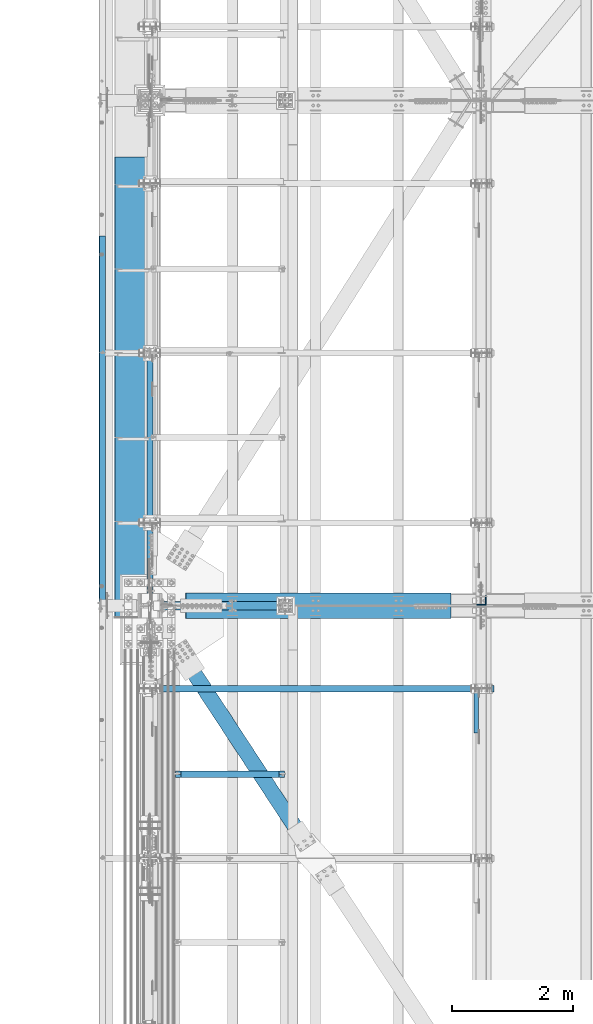
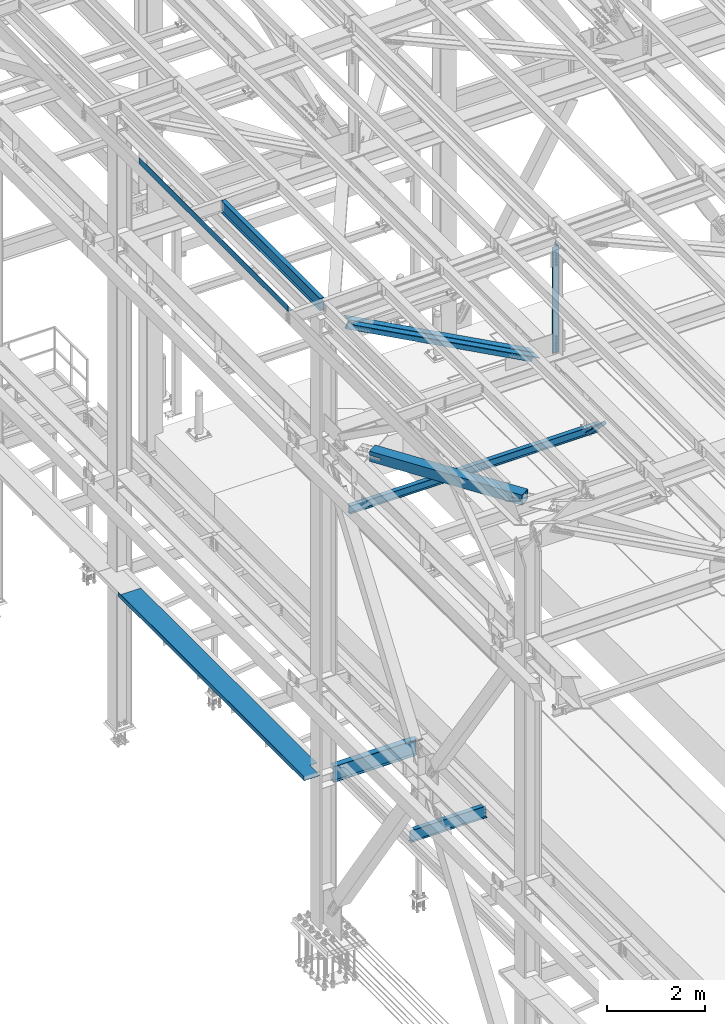
# One storey, part 1873 of 3843: 8 beams, 3 members, 11 elements without a shape of their own.
"""IFC2X3 building model written with IfcOpenShell, lengths in millimetres."""

from ifc_helpers import new_model, si_unit, frame, origin_with_axes, place, context, subcontext, project, spatial, faceted_brep, material, type_object, element, aggregate, save


model = new_model("IFC2X3")

# Units and contexts
model_context = context("Model", 3, precision=1e-05, world=origin_with_axes())
body_context = subcontext(model_context, "Body", "Model", "MODEL_VIEW")
ifc_project = project(units=[si_unit("LENGTHUNIT", "METRE", prefix="MILLI"), si_unit("AREAUNIT", "SQUARE_METRE"), si_unit("VOLUMEUNIT", "CUBIC_METRE"), si_unit("MASSUNIT", "GRAM", prefix="KILO"), si_unit("TIMEUNIT", "SECOND"), si_unit("PLANEANGLEUNIT", "RADIAN"), si_unit("SOLIDANGLEUNIT", "STERADIAN"), si_unit("THERMODYNAMICTEMPERATUREUNIT", "DEGREE_CELSIUS"), si_unit("LUMINOUSINTENSITYUNIT", "LUMEN")], contexts=[model_context])

# Site, building, storey
site_placement = place(None, origin_with_axes())
site = spatial("IfcSite", under=ifc_project, at=site_placement, CompositionType="ELEMENT")
building_placement = place(site_placement, origin_with_axes())
building = spatial("IfcBuilding", under=site, at=building_placement, Name="Undefined", CompositionType="ELEMENT")
storey_placement = place(building_placement, origin_with_axes())
storey = spatial("IfcBuildingStorey", under=building, at=storey_placement, Name="Undefined", CompositionType="ELEMENT", Elevation=0.0)

# Assembly, beam
assembly_1_placement = place(storey_placement, origin_with_axes())
assembly_1 = element("IfcElementAssembly", 1, at=assembly_1_placement, inside=storey, Name="BEAM", AssemblyPlace="NOTDEFINED", PredefinedType="RIGID_FRAME")
ifc_material_1 = material(Name="STEEL/A36")
beam_type_1 = type_object("IfcBeamType", PredefinedType="NOTDEFINED")
beam_1_placement = place(assembly_1_placement, frame((35839.3101110438, 78692.375, 45717.1843160686), z_axis=(0.0, -1.0, 0.0), x_axis=(-0.999776270257024, 0.0, -0.0211520550054595)))
beam_1 = element("IfcBeam", 2, at=beam_1_placement, type_object=beam_type_1, material=ifc_material_1, Name="BENT_PLATE", context=body_context, shape_type="Brep", body=[
    faceted_brep([(-3.50355549016967e-07, -3.17499999742722, -3048.00000001723), (3.50421032635495e-07, -3.17500000260043, 3048.00000001724), (3.5035191103816e-07, 3.17499999739084, 3048.00000001724), (-3.50424670614302e-07, 3.17500000256405, -3048.00000001723), (101.599999864371, 3.17499999856227, 3048.00000000522), (101.599998739839, 3.17500000373548, -3048.00000002925), (95.249998765099, -3.17499999632128, -3048.00000002851), (95.2499998896274, -3.17500000149448, 3048.00000000597), (101.600000309205, -161.925000875126, 3047.9999999938), (101.599999608374, -161.925000446165, -3048.00000004067), (95.2500003092064, -161.925000900388, 3047.99999999456), (95.2499996083752, -161.925000471427, -3048.00000003992)], [[[0, 1, 2, 3]], [[3, 2, 4, 5]], [[1, 0, 6, 7]], [[5, 4, 8, 9]], [[4, 2, 1, 7, 10, 8]], [[7, 6, 11, 10]], [[6, 0, 3, 5, 9, 11]], [[10, 11, 9, 8]]]),
])
aggregate(assembly_1, [beam_1])

assembly_2_placement = place(storey_placement, origin_with_axes())
assembly_2 = element("IfcElementAssembly", 3, at=assembly_2_placement, inside=storey, Name="BEAM", AssemblyPlace="NOTDEFINED", PredefinedType="RIGID_FRAME")
ifc_material_2 = material(Name="STEEL/A992")
beam_type_2 = type_object("IfcBeamType", Name="W12X19", PredefinedType="NOTDEFINED")
beam_2_placement = place(assembly_2_placement, frame((36575.9999999912, 75628.5, 45575.6071293693), z_axis=(0.0, 0.0, 1.0), x_axis=(0.0, 1.0, 0.0)))
beam_2 = element("IfcBeam", 4, at=beam_2_placement, type_object=beam_type_2, material=ifc_material_2, Name="BEAM", ObjectType="W12X19", context=body_context, shape_type="Brep", body=[
    faceted_brep([(15.8750000000146, -3.17500000000291, -128.587499998961), (15.8750000000146, 3.17500000000291, -128.587499998961), (53.9750001907523, 3.17500000000291, -128.587499998961), (53.9750001907523, -3.17500000000291, -128.587499998961), (58.8350797087915, 3.17500000000291, -129.554229921552), (58.8350797087915, -3.17500000000291, -129.554229921552), (62.9552561769524, 3.17500000000291, -132.307243822026), (62.9552561769524, -3.17500000000291, -132.307243822026), (65.7082700774336, 3.17500000000291, -136.42742029018), (65.7082700774336, -3.17500000000291, -136.42742029018), (66.6750000000175, -3.17500000000291, -141.287499808226), (66.6750000000175, 3.17500000000291, -141.287499808226), (66.6750000000175, 3.17500000000291, -144.462500000001), (66.6750000000175, 50.8000000000029, -144.462500000001), (66.6750000000175, 50.8000000000029, -153.987500000003), (66.6750000000175, -50.8000000000029, -153.987500000003), (66.6750000000175, -50.8000000000029, -144.462500000001), (66.6750000000175, -3.17500000000291, -144.462500000001), (4111.62499999991, 50.8000000000029, 144.462500000001), (4111.62499999991, 3.17500000000291, 144.462500000001), (66.6750000000175, 3.17500000000291, 144.462500000001), (66.6750000000175, 50.8000000000029, 144.462500000001), (53.9750001907523, -3.17500000000291, 128.587500001042), (53.9750001907523, 3.17500000000291, 128.587500001042), (15.8750000000146, 3.17500000000291, 128.587500001042), (15.8750000000146, -3.17500000000291, 128.587500001042), (58.8350797087915, -3.17500000000291, 129.554229923633), (58.8350797087915, 3.17500000000291, 129.554229923633), (62.9552561769524, -3.17500000000291, 132.307243824107), (62.9552561769524, 3.17500000000291, 132.307243824107), (65.7082700774336, -3.17500000000291, 136.427420292261), (65.7082700774336, 3.17500000000291, 136.427420292261), (66.6750000000175, -3.17500000000291, 141.287499810307), (66.6750000000175, 3.17500000000291, 141.287499810307), (4111.62499999991, -50.8000000000029, 153.987500000003), (4111.62499999991, 50.8000000000029, 153.987500000003), (66.6750000000175, 50.8000000000029, 153.987500000003), (66.6750000000175, -50.8000000000029, 153.987500000003), (4111.62499999991, -50.8000000000029, 144.462500000001), (66.6750000000175, -50.8000000000029, 144.462500000001), (4111.62499999991, -3.17500000000291, 144.462500000001), (66.6750000000175, -3.17500000000291, 144.462500000001), (4111.62499999991, -3.17500000000291, 141.287499810329), (4111.62499999991, 3.17500000000291, 141.287499810329), (4112.5917299225, -3.17500000000291, 136.427420292282), (4112.5917299225, 3.17500000000291, 136.427420292282), (4115.34474382298, -3.17500000000291, 132.307243824129), (4115.34474382298, 3.17500000000291, 132.307243824129), (4119.46492029114, -3.17500000000291, 129.554229923655), (4119.46492029114, 3.17500000000291, 129.554229923655), (4124.32499980918, -3.17500000000291, 128.587500001064), (4124.32499980918, 3.17500000000291, 128.587500001064), (4162.42499999992, -3.17500000000291, 128.587500001064), (4162.42499999992, 3.17500000000291, 128.587500001064), (4162.42499999992, 3.17500000000291, -114.712499998423), (4162.42499999992, 3.17500000000291, 115.887500001576), (4162.42499999992, -3.17500000000291, -128.587499998939), (4162.42499999992, 3.17500000000291, -128.587499998939), (4124.32499980918, -3.17500000000291, -128.587499998939), (4124.32499980918, 3.17500000000291, -128.587499998939), (4119.46492029114, -3.17500000000291, -129.55422992153), (4119.46492029114, 3.17500000000291, -129.55422992153), (4115.34474382298, -3.17500000000291, -132.307243822004), (4115.34474382298, 3.17500000000291, -132.307243822004), (4112.5917299225, -3.17500000000291, -136.427420290158), (4112.5917299225, 3.17500000000291, -136.427420290158), (4111.62499999991, -3.17500000000291, -141.287499808204), (4111.62499999991, 3.17500000000291, -141.287499808204), (4111.62499999991, -3.17500000000291, -144.462500000001), (4111.62499999991, -50.8000000000029, -144.462500000001), (4111.62499999991, -50.8000000000029, -153.987500000003), (4111.62499999991, 50.8000000000029, -153.987500000003), (4111.62499999991, 50.8000000000029, -144.462500000001), (4111.62499999991, 3.17500000000291, -144.462500000001), (15.8750000000146, 3.17500000000291, -114.712499998386), (15.8750000000146, 3.17500000000291, 115.887500001612)], [[[0, 1, 2, 3]], [[3, 2, 4, 5]], [[5, 4, 6, 7]], [[7, 6, 8, 9]], [[10, 11, 12, 13, 14, 15, 16, 17]], [[9, 8, 11, 10]], [[18, 19, 20, 21]], [[22, 23, 24, 25]], [[26, 27, 23, 22]], [[28, 29, 27, 26]], [[30, 31, 29, 28]], [[32, 33, 31, 30]], [[34, 35, 36, 37]], [[38, 34, 37, 39]], [[40, 38, 39, 41]], [[37, 36, 21, 20, 33, 32, 41, 39]], [[35, 18, 21, 36]], [[34, 38, 40, 42, 43, 19, 18, 35]], [[44, 45, 43, 42]], [[46, 47, 45, 44]], [[48, 49, 47, 46]], [[50, 51, 49, 48]], [[52, 53, 51, 50]], [[54, 55, 53, 52, 56, 57]], [[56, 58, 59, 57]], [[60, 61, 59, 58]], [[62, 63, 61, 60]], [[64, 65, 63, 62]], [[66, 67, 65, 64]], [[68, 69, 70, 71, 72, 73, 67, 66]], [[69, 68, 17, 16]], [[70, 69, 16, 15]], [[71, 70, 15, 14]], [[72, 71, 14, 13]], [[73, 72, 13, 12]], [[6, 4, 2, 1, 74, 75, 24, 23, 27, 29, 31, 33, 20, 19, 43, 45, 47, 49, 51, 53, 55, 54, 57, 59, 61, 63, 65, 67, 73, 12, 11, 8]], [[25, 24, 75, 74, 1, 0]], [[68, 66, 64, 62, 60, 58, 56, 52, 50, 48, 46, 44, 42, 40, 41, 32, 30, 28, 26, 22, 25, 0, 3, 5, 7, 9, 10, 17]]]),
])
aggregate(assembly_2, [beam_2])

# Assembly, member
assembly_3_placement = place(storey_placement, origin_with_axes())
assembly_3 = element("IfcElementAssembly", 5, at=assembly_3_placement, inside=storey, Name="ANGLE", AssemblyPlace="NOTDEFINED", PredefinedType="RIGID_FRAME")
ifc_material_3 = material(Name="STEEL/A572-50")
member_type_1 = type_object("IfcMemberType", Name="L3X3X1/4", PredefinedType="NOTDEFINED")
member_1_placement = place(assembly_3_placement, frame((41973.5, 73248.9368799979, 42308.3631199814), z_axis=(0.0, -0.707106781186548, -0.707106781186548), x_axis=(5.70000238222118e-08, 0.707106781186546, -0.707106781186546)))
member_1 = element("IfcMember", 6, at=member_1_placement, type_object=member_type_1, material=ifc_material_3, Name="ANGLE", ObjectType="L3X3X1/4", context=body_context, shape_type="Brep", body=[
    faceted_brep([(1342.47383399617, -38.0999999999985, -31.7500000069849), (1342.47383399625, -38.0999999999985, -38.1000000070053), (1342.47383399625, 38.0999999999985, -38.1000000070053), (1342.47383399545, 38.0999999999985, 38.0999999932101), (1342.47383399545, 31.75, 38.0999999932101), (1342.47383399617, 31.75, -31.7500000069849), (351.873833995527, 31.75, 38.0999999983032), (351.87383399624, 31.75, -31.7500000018917), (351.87383399624, -38.0999999999985, -31.7500000018917), (351.873833996302, -38.0999999999985, -38.1000000019121), (351.873833996302, 38.0999999999985, -38.1000000019121), (351.873833995527, 38.0999999999985, 38.0999999983032)], [[[0, 1, 2, 3, 4, 5]], [[5, 4, 6, 7]], [[0, 5, 7, 8]], [[1, 0, 8, 9]], [[2, 1, 9, 10]], [[3, 2, 10, 11]], [[4, 3, 11, 6]], [[10, 9, 8, 7, 6, 11]]]),
])
aggregate(assembly_3, [member_1])

# Assembly, beam
assembly_4_placement = place(storey_placement, origin_with_axes())
assembly_4 = element("IfcElementAssembly", 7, at=assembly_4_placement, inside=storey, Name="BEAM", AssemblyPlace="NOTDEFINED", PredefinedType="RIGID_FRAME")
beam_type_3 = type_object("IfcBeamType", Name="W8X13", PredefinedType="NOTDEFINED")
beam_3_placement = place(assembly_4_placement, frame((36372.8, 74256.9, 41402.0), z_axis=(0.0, 0.0, 1.0), x_axis=(1.0, 0.0, 0.0)))
beam_3 = element("IfcBeam", 8, at=beam_3_placement, type_object=beam_type_3, material=ifc_material_2, Name="BEAM", ObjectType="W8X13", context=body_context, shape_type="Brep", body=[
    faceted_brep([(0.0, 50.7999999999993, -101.599999999999), (0.0, 50.7999999999993, -95.25), (5892.8, 50.7999999999993, -95.25), (5892.8, 50.7999999999993, -101.599999999999), (0.0, 3.17499999999927, -95.25), (5892.8, 3.17499999999927, -95.25), (-2.44140610448085e-05, 3.17500000000291, 95.2499999999927), (5892.8, 3.17499999999927, 95.25), (0.0, 50.7999999999993, 95.25), (5892.8, 50.7999999999993, 95.25), (0.0, 50.7999999999993, 101.599999999999), (5892.8, 50.7999999999993, 101.599999999999), (0.0, -50.7999999999993, 101.599999999999), (5892.8, -50.7999999999993, 101.599999999999), (0.0, -50.7999999999993, 95.25), (5892.8, -50.7999999999993, 95.25), (0.0, -3.17499999999927, 95.25), (5892.8, -3.17499999999927, 95.25), (0.0, -3.17499999999927, -95.25), (5892.8, -3.17499999999927, -95.25), (0.0, -50.7999999999993, -95.25), (5892.8, -50.7999999999993, -95.25), (0.0, -50.7999999999993, -101.599999999999), (5892.8, -50.7999999999993, -101.599999999999)], [[[0, 1, 2, 3]], [[1, 4, 5, 2]], [[4, 6, 7, 5]], [[6, 8, 9, 7]], [[8, 10, 11, 9]], [[10, 12, 13, 11]], [[12, 14, 15, 13]], [[14, 16, 17, 15]], [[16, 18, 19, 17]], [[18, 20, 21, 19]], [[20, 22, 23, 21]], [[22, 0, 3, 23]], [[5, 7, 9, 11, 13, 15, 17, 19, 21, 23, 3, 2]], [[22, 20, 18, 16, 14, 12, 10, 8, 6, 4, 1, 0]]]),
])
aggregate(assembly_4, [beam_3])

assembly_5_placement = place(storey_placement, origin_with_axes())
assembly_5 = element("IfcElementAssembly", 9, at=assembly_5_placement, inside=storey, Name="BEAM", AssemblyPlace="NOTDEFINED", PredefinedType="RIGID_FRAME")
beam_type_4 = type_object("IfcBeamType", PredefinedType="NOTDEFINED")
beam_4_placement = place(assembly_5_placement, frame((36537.9000000002, 79238.475, 34039.175), z_axis=(0.0, -1.0, 0.0), x_axis=(-1.0, 0.0, 0.0)))
beam_4 = element("IfcBeam", 10, at=beam_4_placement, type_object=beam_type_4, material=ifc_material_1, Name="BENT_PLATE", context=body_context, shape_type="Brep", body=[
    faceted_brep([(168.275000000205, -3.17500000000291, 3397.24999999999), (168.275000000205, 3.17500000000291, 3397.24999999999), (0.0, 3.17500000000291, 3397.24999999999), (0.0, -3.17500000000291, 3397.24999999999), (168.275000000205, -3.17500000000291, 3810.0), (168.275000000205, 3.17500000000291, 3810.0), (539.749975586143, -3.17500000000291, -3810.0), (0.0, -3.17500000000291, -3810.0), (0.0, 3.17500000000291, -3810.0), (546.099973958539, 3.17500000000291, -3810.0), (546.10000000021, -98.424998372182, -3810.0), (539.750000000204, -98.4249999997846, -3810.0), (546.099973958539, 3.17500000000291, 3810.0), (546.10000000021, -98.424998372182, 3810.0), (539.750000000204, -98.4249999997846, 3810.0), (539.749975586143, -3.17500000000291, 3810.0)], [[[0, 1, 2, 3]], [[4, 5, 1, 0]], [[6, 7, 8, 9, 10, 11]], [[9, 12, 13, 10]], [[14, 11, 10, 13]], [[15, 6, 11, 14]], [[3, 7, 6, 15, 4, 0]], [[8, 7, 3, 2]], [[12, 9, 8, 2, 1, 5]], [[15, 14, 13, 12, 5, 4]]]),
])
aggregate(assembly_5, [beam_4])

# Assembly, member
assembly_6_placement = place(storey_placement, origin_with_axes())
assembly_6 = element("IfcElementAssembly", 11, at=assembly_6_placement, inside=storey, Name="ANGLE", AssemblyPlace="NOTDEFINED", PredefinedType="RIGID_FRAME")
member_type_2 = type_object("IfcMemberType", Name="L8X8X1/2", PredefinedType="NOTDEFINED")
member_2_placement = place(assembly_6_placement, frame((36576.0000011997, 75739.625, 45221.460476912), z_axis=(-0.473425498802528, 0.0, -0.880833864632587), x_axis=(0.880833864632588, 0.0, -0.473425498802525)))
member_2 = element("IfcMember", 12, at=member_2_placement, type_object=member_type_2, material=ifc_material_3, Name="ANGLE", ObjectType="L8X8X1/2", context=body_context, shape_type="Brep", body=[
    faceted_brep([(624.015457992366, 101.600000000006, -101.600000001949), (624.015457992369, 101.600000000006, 101.599999998049), (5603.53397359396, 101.600000000006, 101.599999982536), (5603.53397359397, 101.600000000006, -101.600000017468), (624.015457992369, 88.8999999999942, 101.599999998049), (5603.53397359396, 88.8999999999942, 101.599999982536), (624.015457992369, 88.8999999999942, -88.9000000019441), (5603.53397359396, 88.8999999999942, -88.9000000174638), (624.015457992369, -101.600000000006, -88.9000000019441), (5603.53397359396, -101.600000000006, -88.9000000174638), (624.015457992366, -101.600000000006, -101.600000001949), (5603.53397359397, -101.600000000006, -101.600000017468)], [[[0, 1, 2, 3]], [[1, 4, 5, 2]], [[4, 6, 7, 5]], [[6, 8, 9, 7]], [[8, 10, 11, 9]], [[10, 0, 3, 11]], [[5, 7, 9, 11, 3, 2]], [[10, 8, 6, 4, 1, 0]]]),
])
aggregate(assembly_6, [member_2])

assembly_7_placement = place(storey_placement, origin_with_axes())
assembly_7 = element("IfcElementAssembly", 13, at=assembly_7_placement, inside=storey, Name="ANGLE", AssemblyPlace="NOTDEFINED", PredefinedType="RIGID_FRAME")
member_3_placement = place(assembly_7_placement, frame((42062.4000014806, 75517.375, 42272.6618865631), z_axis=(-0.473425498802528, 0.0, -0.880833864632587), x_axis=(-0.880833864632589, 0.0, 0.473425498802524)))
member_3 = element("IfcMember", 14, at=member_3_placement, type_object=member_type_2, material=ifc_material_3, Name="ANGLE", ObjectType="L8X8X1/2", context=body_context, shape_type="Brep", body=[
    faceted_brep([(625.109385077511, 101.600000000006, -101.599999998056), (625.109385077511, 101.600000000006, 101.600000001934), (5604.6279006791, 101.600000000006, 101.600000017454), (5604.6279006791, 101.600000000006, -101.599999982544), (625.109385077511, 88.8999999999942, 101.600000001934), (5604.6279006791, 88.8999999999942, 101.600000017454), (625.109385077503, 88.8999999999942, -88.8999999980588), (5604.62790067911, 88.8999999999942, -88.8999999825464), (625.109385077503, -101.600000000006, -88.8999999980588), (5604.62790067911, -101.600000000006, -88.8999999825464), (625.109385077511, -101.600000000006, -101.599999998056), (5604.6279006791, -101.600000000006, -101.599999982544)], [[[0, 1, 2, 3]], [[1, 4, 5, 2]], [[4, 6, 7, 5]], [[6, 8, 9, 7]], [[8, 10, 11, 9]], [[10, 0, 3, 11]], [[5, 7, 9, 11, 3, 2]], [[10, 8, 6, 4, 1, 0]]]),
])
aggregate(assembly_7, [member_3])

# Assembly, beam
assembly_8_placement = place(storey_placement, origin_with_axes())
assembly_8 = element("IfcElementAssembly", 15, at=assembly_8_placement, inside=storey, Name="ANGLE", AssemblyPlace="NOTDEFINED", PredefinedType="RIGID_FRAME")
beam_type_5 = type_object("IfcBeamType", Name="L6X6X1/2", PredefinedType="NOTDEFINED")
beam_5_placement = place(assembly_8_placement, frame((42062.4, 75714.2249999998, 45363.6596289107), z_axis=(-1.0, 0.0, 0.0), x_axis=(0.0, 0.0, -1.0)))
beam_5 = element("IfcBeam", 16, at=beam_5_placement, type_object=beam_type_5, material=ifc_material_3, Name="ANGLE", ObjectType="L6X6X1/2", context=body_context, shape_type="Brep", body=[
    faceted_brep([(223.762637065054, 76.1999999999971, -76.1999999999971), (223.762637065054, 76.1999999999971, 76.1999999999971), (2881.03892597825, 76.1999999999971, 76.1999999999971), (2881.03892597825, 76.1999999999971, -76.1999999999971), (223.762637065054, 63.5, 76.1999999999971), (2881.03892597825, 63.5, 76.1999999999971), (223.762637065054, 63.5, -63.5), (2881.03892597825, 63.5, -63.5), (223.762637065054, -76.1999999999971, -63.5), (2881.03892597825, -76.1999999999971, -63.5), (223.762637065054, -76.1999999999971, -76.1999999999971), (2881.03892597825, -76.1999999999971, -76.1999999999971)], [[[0, 1, 2, 3]], [[1, 4, 5, 2]], [[4, 6, 7, 5]], [[6, 8, 9, 7]], [[8, 10, 11, 9]], [[10, 0, 3, 11]], [[5, 7, 9, 11, 3, 2]], [[10, 8, 6, 4, 1, 0]]]),
])
aggregate(assembly_8, [beam_5])

assembly_9_placement = place(storey_placement, origin_with_axes())
assembly_9 = element("IfcElementAssembly", 17, at=assembly_9_placement, inside=storey, AssemblyPlace="NOTDEFINED", PredefinedType="RIGID_FRAME")
ifc_material_4 = material()
beam_type_6 = type_object("IfcBeamType", Name="HSS10X10X3/4", PredefinedType="NOTDEFINED")
beam_6_placement = place(assembly_9_placement, frame((36576.0, 75628.5, 42246.55), z_axis=(0.835938629021657, 0.548822930014219, 0.0), x_axis=(0.548822930014218, -0.835938629021658, 0.0)))
beam_6 = element("IfcBeam", 18, at=beam_6_placement, type_object=beam_type_6, material=ifc_material_4, ObjectType="HSS10X10X3/4", context=body_context, shape_type="Brep", body=[
    faceted_brep([(4607.8393605934, 1.58750000000146, 127.000000003842), (4355.42686058164, 1.58750000000146, 127.000000003667), (4355.42686058166, 1.58750000000146, 107.950000003577), (4607.83936059341, 1.58750000000146, 107.950000003759), (4352.38931083721, 0.983293789307936, 127.000000003667), (4352.38931083722, 0.983293789307936, 107.950000003577), (4349.8142005059, -0.737339924329717, 127.00000000366), (4349.81420050591, -0.737339924329717, 107.950000003577), (4348.09356679223, -3.31245025560202, 127.00000000366), (4348.09356679225, -3.31245025560202, 107.95000000357), (4347.48936058155, -6.34999999999854, 127.000000003653), (4347.48936058156, -6.34999999999854, 107.950000003577), (4348.09356679223, -9.38754974439507, 127.00000000366), (4348.09356679225, -9.38754974439507, 107.95000000357), (4349.8142005059, -11.9626600756674, 127.00000000366), (4349.81420050591, -11.9626600756674, 107.950000003577), (4352.38931083721, -13.683293789305, 127.000000003667), (4352.38931083722, -13.683293789305, 107.950000003577), (4355.42686058164, -14.2874999999985, 127.000000003667), (4355.42686058166, -14.2874999999985, 107.950000003577), (4607.8393605934, -14.2874999999985, 127.000000003842), (4607.83936059341, -14.2874999999985, 107.950000003759), (4607.83936059341, 1.58750000000146, -107.949999997174), (4355.42686058181, 1.58750000000146, -107.949999997363), (4355.42686058182, 1.58750000000146, -126.999999997439), (4607.83936059341, 1.58750000000146, -126.999999997264), (4352.38931083737, 0.983293789307936, -107.949999997356), (4352.38931083739, 0.983293789307936, -126.999999997439), (4349.81420050607, -0.737339924329717, -107.949999997363), (4349.81420050608, -0.737339924329717, -126.999999997439), (4348.0935667924, -3.31245025560202, -107.949999997363), (4348.09356679242, -3.31245025560202, -126.999999997439), (4347.48936058171, -6.34999999999854, -107.949999997363), (4347.48936058172, -6.34999999999854, -126.999999997453), (4348.0935667924, -9.38754974439507, -107.949999997363), (4348.09356679242, -9.38754974439507, -126.999999997439), (4349.81420050607, -11.9626600756674, -107.949999997363), (4349.81420050608, -11.9626600756674, -126.999999997439), (4352.38931083737, -13.683293789305, -107.949999997356), (4352.38931083739, -13.683293789305, -126.999999997439), (4355.42686058181, -14.2874999999985, -107.949999997363), (4355.42686058182, -14.2874999999985, -126.999999997439), (4607.83936059341, -14.2874999999985, -107.949999997174), (4607.83936059341, -14.2874999999985, -126.999999997264), (1109.41820844431, 107.949999999997, 107.95000000127), (1109.41820844432, 107.949999999997, -107.949999999662), (4607.83936059341, 107.949999999997, -107.949999997174), (4607.83936059341, 107.949999999997, 107.950000003759), (4607.83936059341, -107.949999999997, 107.950000003759), (1109.41820844431, -107.949999999997, 107.95000000127), (1109.41820844496, -26.989127884066, 107.950000000827), (1361.83070804884, -26.989127884066, 107.950000001001), (1367.29829773481, -25.9015566757807, 107.950000001001), (1371.93349645492, -22.8044159085402, 107.950000001001), (1375.0306372222, -18.1692171884933, 107.950000001001), (1376.1182084305, -12.7016275025962, 107.950000001016), (1375.0306372222, -7.23403857964149, 107.950000001001), (1371.93349645492, -2.59883985959459, 107.950000001001), (1367.29829773481, 0.498300907645898, 107.950000001001), (1361.83070804884, 1.58587211593112, 107.950000001001), (1109.41820844496, 1.58587211593112, 107.950000000827), (1109.41820844432, -107.949999999997, -107.949999999662), (4607.83936059341, -107.949999999997, -107.949999997174), (1109.41820844365, 1.58587211593112, -107.949999999255), (1361.83070804638, 1.58587211593112, -107.94999999908), (1367.29829773234, 0.498300907645898, -107.949999999066), (1371.93349645245, -2.59883985959459, -107.949999999066), (1375.03063721974, -7.23403857964149, -107.949999999066), (1376.11820842803, -12.7016275025962, -107.949999999066), (1375.03063721974, -18.1692171884933, -107.949999999066), (1371.93349645245, -22.8044159085402, -107.949999999066), (1367.29829773234, -25.9015566757807, -107.949999999066), (1361.83070804638, -26.989127884066, -107.94999999908), (1109.41820844365, -26.989127884066, -107.949999999255), (1109.41820844353, 1.58587211593112, -126.999999999258), (1361.83070804615, 1.58587211593112, -126.999999999069), (1367.29829773212, 0.498300907645898, -126.999999999069), (1371.93349645223, -2.59883985959459, -126.999999999069), (1375.03063721952, -7.23403857964149, -126.999999999069), (1376.11820842782, -12.7016275025962, -126.999999999069), (1375.03063721952, -18.1692171884933, -126.999999999069), (1371.93349645223, -22.8044159085402, -126.999999999069), (1367.29829773212, -25.9015566757807, -126.999999999069), (1361.83070804615, -26.989127884066, -126.999999999069), (1109.41820844353, -26.989127884066, -126.999999999258), (1109.41820844431, -127.0, -126.999999999753), (1109.41820844431, -127.0, 127.000000001353), (1109.41820844509, -26.989127884066, 127.000000000829), (1361.83070804906, -26.989127884066, 127.000000001019), (1367.29829773503, -25.9015566757807, 127.000000001019), (1371.93349645513, -22.8044159085402, 127.000000001019), (1375.03063722243, -18.1692171884933, 127.000000001019), (1376.11820843071, -12.7016275025962, 127.000000001019), (1375.03063722243, -7.23403857964149, 127.000000001019), (1371.93349645513, -2.59883985959459, 127.000000001019), (1367.29829773503, 0.498300907645898, 127.000000001019), (1361.83070804906, 1.58587211593112, 127.000000001019), (1109.41820844509, 1.58587211593112, 127.000000000829), (1109.41820844431, 127.0, 127.000000001353), (1109.41820844431, 127.0, -126.999999999753), (4607.8393605934, 127.0, 127.000000003842), (4607.83936059341, 127.0, -126.999999997264), (4607.83936059341, -127.0, -126.999999997264), (4607.8393605934, -127.0, 127.000000003842)], [[[0, 1, 2, 3]], [[4, 5, 2, 1]], [[6, 7, 5, 4]], [[8, 9, 7, 6]], [[10, 11, 9, 8]], [[12, 13, 11, 10]], [[14, 15, 13, 12]], [[16, 17, 15, 14]], [[18, 19, 17, 16]], [[20, 21, 19, 18]], [[22, 23, 24, 25]], [[26, 27, 24, 23]], [[28, 29, 27, 26]], [[30, 31, 29, 28]], [[32, 33, 31, 30]], [[34, 35, 33, 32]], [[36, 37, 35, 34]], [[38, 39, 37, 36]], [[40, 41, 39, 38]], [[42, 43, 41, 40]], [[44, 45, 46, 47]], [[48, 49, 50, 51, 52, 53, 54, 55, 56, 57, 58, 59, 60, 44, 47, 3, 2, 5, 7, 9, 11, 13, 15, 17, 19, 21]], [[61, 49, 48, 62]], [[38, 36, 34, 32, 30, 28, 26, 23, 22, 46, 45, 63, 64, 65, 66, 67, 68, 69, 70, 71, 72, 73, 61, 62, 42, 40]], [[63, 74, 75, 64]], [[64, 75, 76, 65]], [[65, 76, 77, 66]], [[66, 77, 78, 67]], [[67, 78, 79, 68]], [[68, 79, 80, 69]], [[69, 80, 81, 70]], [[70, 81, 82, 71]], [[71, 82, 83, 72]], [[72, 83, 84, 73]], [[49, 61, 73, 84, 85, 86, 87, 50]], [[88, 51, 50, 87]], [[89, 52, 51, 88]], [[90, 53, 52, 89]], [[91, 54, 53, 90]], [[92, 55, 54, 91]], [[93, 56, 55, 92]], [[94, 57, 56, 93]], [[95, 58, 57, 94]], [[96, 59, 58, 95]], [[97, 60, 59, 96]], [[98, 99, 74, 63, 45, 44, 60, 97]], [[99, 98, 100, 101]], [[47, 46, 22, 25, 101, 100, 0, 3]], [[102, 85, 84, 83, 82, 81, 80, 79, 78, 77, 76, 75, 74, 99, 101, 25, 24, 27, 29, 31, 33, 35, 37, 39, 41, 43]], [[86, 85, 102, 103]], [[16, 14, 12, 10, 8, 6, 4, 1, 0, 100, 98, 97, 96, 95, 94, 93, 92, 91, 90, 89, 88, 87, 86, 103, 20, 18]], [[103, 102, 43, 42, 62, 48, 21, 20]]]),
])
aggregate(assembly_9, [beam_6])

assembly_10_placement = place(storey_placement, origin_with_axes())
assembly_10 = element("IfcElementAssembly", 19, at=assembly_10_placement, inside=storey, Name="BEAM", AssemblyPlace="NOTDEFINED", PredefinedType="RIGID_FRAME")
beam_type_7 = type_object("IfcBeamType", Name="W16X26", PredefinedType="NOTDEFINED")
beam_7_placement = place(assembly_10_placement, frame((36576.0, 75628.5, 33835.975), z_axis=(0.0, 0.0, 1.0), x_axis=(1.0, 0.0, 0.0)))
beam_7 = element("IfcBeam", 20, at=beam_7_placement, type_object=beam_type_7, material=ifc_material_2, Name="BEAM", ObjectType="W16X26", context=body_context, shape_type="Brep", body=[
    faceted_brep([(2130.42500076294, 50.8000007629307, 200.025000000016), (2130.42500076294, 50.8000007629307, 190.5), (2130.42500076294, 69.8500000000058, 190.5), (2130.42500076294, 69.8500000000058, 200.025000000001), (2181.22500000001, 50.8000007629307, 200.025000000016), (2181.225, 50.8000007629307, 190.5), (2130.42500076294, 50.8000007629307, -190.5), (2130.42500076294, 50.8000007629307, -200.025000000001), (2130.42500076294, 69.8500000000058, -200.025000000001), (2130.42500076294, 69.8500000000058, -190.5), (2181.22500000001, 50.8000007629307, -190.5), (2181.225, 50.8000007629307, -200.025000000001), (2130.42500076294, -69.8500000000058, -190.5), (2130.42500076294, -69.8500000000058, -200.025000000001), (2130.42500076294, -50.8000007629307, -200.025000000001), (2130.42500076294, -50.8000007629307, -190.5), (212.724999999999, -69.8500000000058, -190.5), (212.724999999999, -69.8500000000058, -200.025000000001), (2130.42500076294, -69.8500000000058, 200.025000000001), (2130.42500076294, -69.8500000000058, 190.5), (2130.42500076294, -50.8000007629307, 190.5), (2130.42500076294, -50.8000007629307, 200.025000000016), (212.724999999999, -69.8500000000058, 200.025000000001), (212.724999999999, -69.8500000000058, 190.5), (212.724999999999, -3.17500000000291, -190.5), (212.724999999999, -3.17500000000291, 190.5), (212.724999999999, 69.8500000000058, 200.025000000001), (212.724999999999, 69.8500000000058, 190.5), (212.724999999999, 3.17500000000291, 190.5), (212.724999999999, 3.17500000000291, -190.5), (212.724999999999, 69.8500000000058, -190.5), (212.724999999999, 69.8500000000058, -200.025000000001), (2181.225, 3.17500000000291, 190.5), (2181.225, 3.17500000000291, -190.5), (2181.225, -50.8000007629307, -200.025000000001), (2181.22500000001, -50.8000007629307, -190.5), (2181.225, -3.17500000000291, -190.5), (2181.225, -3.17500000000291, 190.5), (2181.225, -50.8000007629307, 190.5), (2181.22500000001, -50.8000007629307, 200.025000000016)], [[[0, 1, 2, 3]], [[4, 5, 1, 0]], [[6, 7, 8, 9]], [[10, 11, 7, 6]], [[12, 13, 14, 15]], [[16, 17, 13, 12]], [[18, 19, 20, 21]], [[22, 23, 19, 18]], [[17, 16, 24, 25, 23, 22, 26, 27, 28, 29, 30, 31]], [[27, 26, 3, 2]], [[32, 28, 27, 2, 1, 5]], [[29, 28, 32, 33]], [[9, 30, 29, 33, 10, 6]], [[31, 30, 9, 8]], [[34, 14, 13, 17, 31, 8, 7, 11]], [[35, 15, 14, 34]], [[36, 24, 16, 12, 15, 35]], [[25, 24, 36, 37]], [[19, 23, 25, 37, 38, 20]], [[39, 21, 20, 38]], [[3, 26, 22, 18, 21, 39, 4, 0]], [[39, 38, 37, 36, 35, 34, 11, 10, 33, 32, 5, 4]]]),
])
aggregate(assembly_10, [beam_7])

assembly_11_placement = place(storey_placement, origin_with_axes())
assembly_11 = element("IfcElementAssembly", 21, at=assembly_11_placement, inside=storey, Name="BEAM", AssemblyPlace="NOTDEFINED", PredefinedType="RIGID_FRAME")
beam_type_8 = type_object("IfcBeamType", Name="W12X14", PredefinedType="NOTDEFINED")
beam_8_placement = place(assembly_11_placement, frame((36982.4, 72842.834376, 33885.1875), z_axis=(0.0, 0.0, 1.0), x_axis=(1.0, 0.0, 0.0)))
beam_8 = element("IfcBeam", 22, at=beam_8_placement, type_object=beam_type_8, material=ifc_material_2, Name="BEAM", ObjectType="W12X14", context=body_context, shape_type="Brep", body=[
    faceted_brep([(92.8687501907334, -2.38125000000582, 125.412499999991), (92.8687501907334, 2.38125000000582, 125.412499999991), (16.6687499999971, 2.38125000000582, 125.412499999991), (16.6687499999971, -2.38125000000582, 125.412499999991), (97.7288297087798, -2.38125000000582, 126.379229922582), (97.7288297087798, 2.38125000000582, 126.379229922582), (101.849006176933, -2.38125000000582, 129.132243823056), (101.849006176933, 2.38125000000582, 129.132243823056), (104.602020077407, -2.38125000000582, 133.25242029121), (104.602020077407, 2.38125000000582, 133.25242029121), (105.568749999999, -2.38125000000582, 138.112499809256), (105.568749999999, 2.38125000000582, 138.112499809256), (105.568749999999, -50.8000000000029, 150.812499810811), (105.568749999999, 50.8000000000029, 150.8125), (105.568749999999, 50.8000000000029, 144.462500000001), (105.568749999999, 2.38125000000582, 144.462500000001), (105.568749999999, -2.38125000000582, 144.462500000001), (105.568749999999, -50.8000000000029, 144.462500000001), (16.6687499999971, -2.38125000000582, -144.462500000001), (16.6687499999971, -50.7999999999993, -144.462500000001), (1821.65625, -50.8000000000029, -144.462500000001), (1821.65625, -2.38125000000582, -144.462500000001), (16.6687499999971, -50.8000000000029, -150.8125), (1821.65625, -50.8000000000029, -150.8125), (16.6687499999971, 50.8000000000029, -150.8125), (1821.65625, 50.8000000000029, -150.8125), (16.6687499999971, 50.7999999999993, -144.462500000001), (1821.65625, 50.8000000000029, -144.462500000001), (16.6687499999971, 2.38125000000582, -144.462500000001), (1821.65625, 2.38125000000582, -144.462500000001), (1821.65625, 2.38125000000582, -117.887499999997), (1821.65625, 2.38125000000582, 112.712500000001), (1821.65625, 2.38125000000582, 125.412499999991), (1821.65625, -2.38125000000582, 125.412499999991), (1745.45624980926, 2.38125000000582, 125.412499999991), (1745.45624980926, -2.38125000000582, 125.412499999991), (1740.59617029122, 2.38125000000582, 126.379229922582), (1740.59617029122, -2.38125000000582, 126.379229922582), (1736.47599382306, 2.38125000000582, 129.132243823056), (1736.47599382306, -2.38125000000582, 129.132243823056), (1733.72297992259, 2.38125000000582, 133.25242029121), (1733.72297992259, -2.38125000000582, 133.25242029121), (1732.75625, 2.38125000000582, 138.112499809256), (1732.75625, -2.38125000000582, 138.112499809256), (1732.75625, -50.8000000000029, 150.8125), (1732.75625, -50.8000000000029, 144.462500000001), (1732.75625, -2.38125000000582, 144.462500000001), (1732.75625, 2.38125000000582, 144.462500000001), (1732.75625, 50.8000000000029, 144.462500000001), (1732.75625, 50.8000000000029, 150.8125), (16.6687499999971, 2.38125000000582, 112.712500000001), (16.6687499999971, 2.38125000000582, -117.887499999997)], [[[0, 1, 2, 3]], [[4, 5, 1, 0]], [[6, 7, 5, 4]], [[8, 9, 7, 6]], [[10, 11, 9, 8]], [[12, 13, 14, 15, 11, 10, 16, 17]], [[18, 19, 20, 21]], [[19, 22, 23, 20]], [[22, 24, 25, 23]], [[24, 26, 27, 25]], [[26, 28, 29, 27]], [[21, 20, 23, 25, 27, 29, 30, 31, 32, 33]], [[33, 32, 34, 35]], [[35, 34, 36, 37]], [[37, 36, 38, 39]], [[39, 38, 40, 41]], [[41, 40, 42, 43]], [[44, 45, 46, 43, 42, 47, 48, 49]], [[45, 44, 12, 17]], [[46, 45, 17, 16]], [[8, 6, 4, 0, 3, 18, 21, 33, 35, 37, 39, 41, 43, 46, 16, 10]], [[50, 51, 28, 26, 24, 22, 19, 18, 3, 2]], [[47, 42, 40, 38, 36, 34, 32, 31, 30, 29, 28, 51, 50, 2, 1, 5, 7, 9, 11, 15]], [[48, 47, 15, 14]], [[49, 48, 14, 13]], [[44, 49, 13, 12]]]),
])
aggregate(assembly_11, [beam_8])

save(model, "model.ifc")
